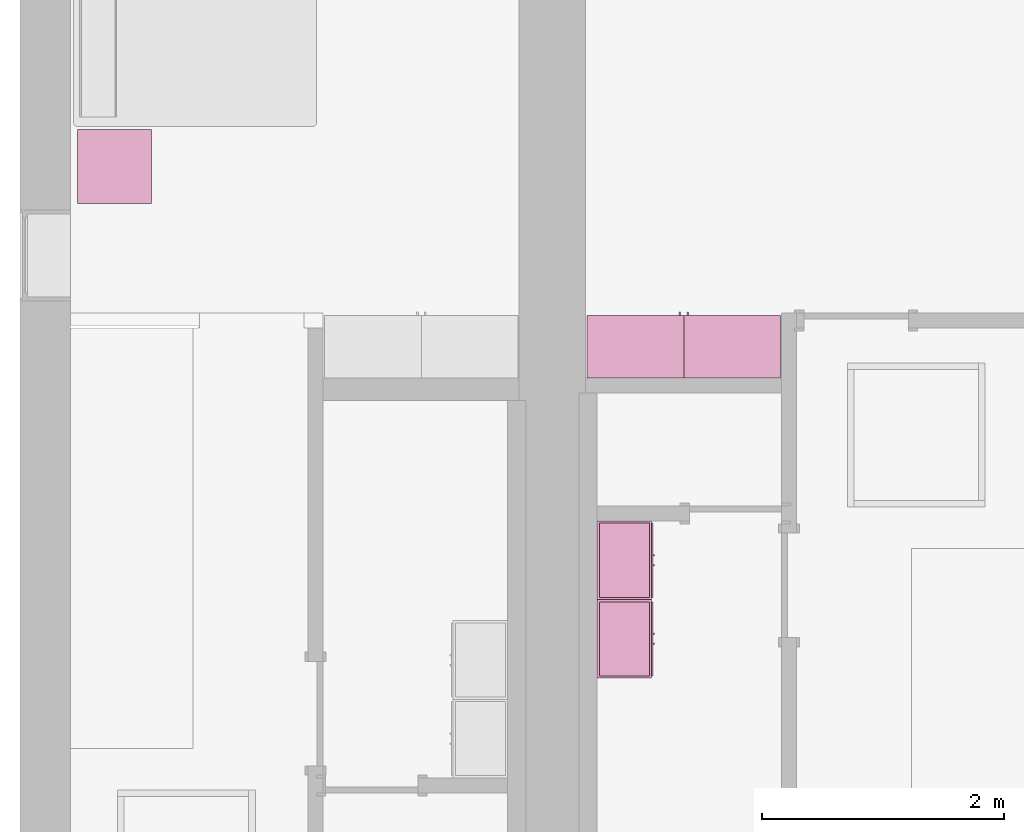
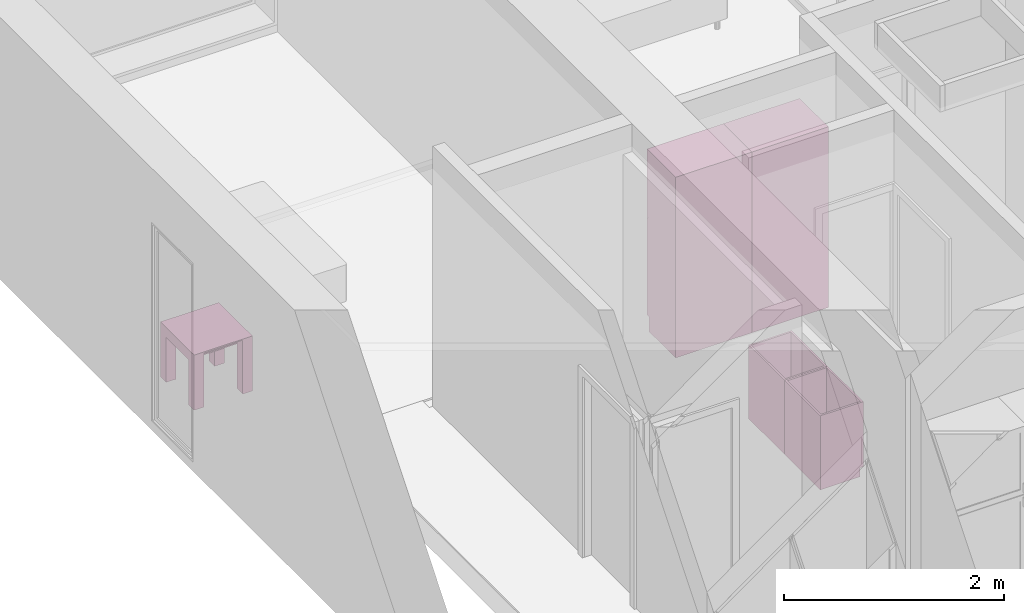
# One storey, part 11 of 14: 5 furnishings, 2 openings.
"""IFC2X3 building model written with IfcOpenShell, lengths in metres."""

import ifcopenshell
import ifcopenshell.guid

model = None  # the IFC model being written
_history = None  # IfcOwnerHistory: only IFC2X3 demands one
_inside = {}  # id of a spatial element -> (the spatial element, [elements in it])
_under = {}  # id of a project, library or spatial element -> (it, [spatial elements below it])
_declared = {}  # id of a project -> (the project, [libraries it declares])
_typed = {}  # id of a type object -> (the type object, [elements of that type])
_made_of = {}  # id of a material, layer set ... -> (it, [elements and type objects made of it])


def new_model(schema):
    """Start an empty IFC model of exactly this schema.

    Asked for "IFC4X3", IfcOpenShell would pick the latest addendum, in which some entities
    have other attributes; the version numbers below select the first issue.
    IFC2X3 requires an IfcOwnerHistory on every rooted entity: one is made here for all.
    """
    global model, _history
    if schema == "IFC4X3":
        model = ifcopenshell.file(schema_version=(4, 3, 0, 0))
    else:
        model = ifcopenshell.file(schema=schema)
    _inside.clear()
    _under.clear()
    _declared.clear()
    _typed.clear()
    _made_of.clear()
    _history = None
    if model.schema == "IFC2X3":
        org = make("IfcOrganization", Name="unknown")
        user = make(
            "IfcPersonAndOrganization",
            ThePerson=make("IfcPerson", FamilyName="unknown"),
            TheOrganization=org,
        )
        app = make(
            "IfcApplication",
            ApplicationDeveloper=org,
            Version="unknown",
            ApplicationFullName="unknown",
            ApplicationIdentifier="unknown",
        )
        _history = make(
            "IfcOwnerHistory",
            OwningUser=user,
            OwningApplication=app,
            ChangeAction="ADDED",
            CreationDate=0,
        )
    return model


def make(cls, **values):
    """One entity of the class cls with the attributes given. An attribute that is None is left unset."""
    return model.create_entity(
        cls, **{name: value for name, value in values.items() if value is not None}
    )


def entity(cls, *values):
    """Any entity or typed value of the class cls, its attributes in the order of the schema. None: left unset."""
    e = model.create_entity(cls)
    for i, value in enumerate(values):
        if value is not None:
            e[i] = value
    return e


def rooted(cls, **values):
    """An entity with a GlobalId (a new one), such as an element, a storey or a relation."""
    return make(cls, GlobalId=ifcopenshell.guid.new(), OwnerHistory=_history, **values)


def si_unit(unit_type, name, prefix=None):
    """IfcSIUnit, for example si_unit("LENGTHUNIT", "METRE", prefix="MILLI")."""
    return make("IfcSIUnit", UnitType=unit_type, Prefix=prefix, Name=name)


def converted_unit(unit_type, name, factor, base, dimensions=None, offset=None):
    """IfcConversionBasedUnit, such as the inch: factor (a typed value) times the base unit."""
    return make(
        "IfcConversionBasedUnit"
        if offset is None
        else "IfcConversionBasedUnitWithOffset",
        ConversionOffset=offset,
        Dimensions=None
        if dimensions is None
        else entity("IfcDimensionalExponents", *dimensions),
        UnitType=unit_type,
        Name=name,
        ConversionFactor=make(
            "IfcMeasureWithUnit", ValueComponent=factor, UnitComponent=base
        ),
    )


def assignment(units):
    """IfcUnitAssignment: the units of a project."""
    return None if units is None else make("IfcUnitAssignment", Units=units)


def point(xyz):
    """IfcCartesianPoint."""
    return None if xyz is None else make("IfcCartesianPoint", Coordinates=xyz)


def direction(xyz):
    """IfcDirection."""
    return None if xyz is None else make("IfcDirection", DirectionRatios=xyz)


def frame(location, z_axis=None, x_axis=None):
    """IfcAxis2Placement3D, a coordinate frame: its origin and axes. An axis left out is left unset."""
    return make(
        "IfcAxis2Placement3D",
        Location=point(location),
        Axis=direction(z_axis),
        RefDirection=direction(x_axis),
    )


def frame_2d(location, x_axis=None):
    """IfcAxis2Placement2D, a coordinate frame in the plane: its origin and x axis."""
    return make(
        "IfcAxis2Placement2D", Location=point(location), RefDirection=direction(x_axis)
    )


def origin():
    """The frame at (0, 0, 0) with its axes left unset."""
    return frame((0.0, 0.0, 0.0))


def origin_2d_with_axis():
    """The frame at (0, 0) in the plane with the x axis (1, 0) written out."""
    return frame_2d((0.0, 0.0), x_axis=(1.0, 0.0))


def place(relative_to, where):
    """IfcLocalPlacement: puts the frame where relative to a parent placement (None: the world)."""
    return make(
        "IfcLocalPlacement", PlacementRelTo=relative_to, RelativePlacement=where
    )


def context(
    kind, dimensions, precision=None, world=None, true_north=None, identifier=None
):
    """IfcGeometricRepresentationContext, for example the 3D "Model" context."""
    return make(
        "IfcGeometricRepresentationContext",
        ContextIdentifier=identifier,
        ContextType=kind,
        CoordinateSpaceDimension=dimensions,
        Precision=precision,
        WorldCoordinateSystem=world,
        TrueNorth=true_north,
    )


def project(units=None, contexts=None):
    """IfcProject with its units and contexts."""
    return rooted(
        "IfcProject",
        Name="project",
        RepresentationContexts=contexts,
        UnitsInContext=assignment(units),
    )


def spatial(cls, under=None, at=None, **own):
    """A site, building, storey or space (cls), placed at a placement, below another one or the project."""
    s = rooted(cls, ObjectPlacement=at, **own)
    if under is not None:
        _under.setdefault(under.id(), (under, []))[1].append(s)
    return s


def polyline(points):
    """IfcPolyline through the points."""
    return make("IfcPolyline", Points=[point(p) for p in points])


def profile(cls, at=None, kind="AREA", **sizes):
    """A parametric profile (cls). Its sizes go by their IFC names, for example OverallWidth=200.0."""
    return make(cls, ProfileType=kind, Position=at, **sizes)


def rectangle(**sizes):
    """IfcRectangleProfileDef."""
    return profile("IfcRectangleProfileDef", **sizes)


def outline(outer, holes=None, kind="AREA"):
    """IfcArbitraryClosedProfileDef: a profile drawn as a closed curve; with holes, ...WithVoids."""
    if holes is None:
        return make("IfcArbitraryClosedProfileDef", ProfileType=kind, OuterCurve=outer)
    return make(
        "IfcArbitraryProfileDefWithVoids",
        ProfileType=kind,
        OuterCurve=outer,
        InnerCurves=holes,
    )


def extrude(swept, where, along, depth):
    """IfcExtrudedAreaSolid: the profile swept, set in the frame where, extruded along a direction by depth."""
    return make(
        "IfcExtrudedAreaSolid",
        SweptArea=swept,
        Position=where,
        ExtrudedDirection=direction(along),
        Depth=depth,
    )


def faces_of(points, faces, orient=None, outer=None):
    """IfcFace entities. A face is a list of loops; a loop is a list of indices into points, from 0.

    orient and outer hold one flag for each loop. By default every Orientation is true, the
    first loop of a face is its IfcFaceOuterBound and the others are IfcFaceBound.
    """
    made = []
    for i, loops in enumerate(faces):
        bounds = []
        for j, loop in enumerate(loops):
            is_outer = j == 0 if outer is None else outer[i][j]
            bounds.append(
                make(
                    "IfcFaceOuterBound" if is_outer else "IfcFaceBound",
                    Bound=make("IfcPolyLoop", Polygon=[points[k] for k in loop]),
                    Orientation=True if orient is None else orient[i][j],
                )
            )
        made.append(make("IfcFace", Bounds=bounds))
    return made


def face_set(faces, orient=None, outer=None):
    """The faces of one IfcConnectedFaceSet. surface_model builds it on its shared points."""
    return ("IfcConnectedFaceSet", faces, orient, outer)


def surface_model(cls, points, shells):
    """IfcFaceBasedSurfaceModel or IfcShellBasedSurfaceModel (cls): surfaces that need not close."""
    shared = [point(p) for p in points]
    made = [make(c, CfsFaces=faces_of(shared, fs, o, b)) for c, fs, o, b in shells]
    if cls == "IfcFaceBasedSurfaceModel":
        return make(cls, FbsmFaces=made)
    return make(cls, SbsmBoundary=made)


def shape(context_of_items, identifier, shape_type, items):
    """IfcShapeRepresentation: the items that make up one representation, for example the "Body"."""
    return make(
        "IfcShapeRepresentation",
        ContextOfItems=context_of_items,
        RepresentationIdentifier=identifier,
        RepresentationType=shape_type,
        Items=items,
    )


def source(mapping_origin, context_of_items, identifier, shape_type, items):
    """IfcRepresentationMap: a shape defined once, which mapped items show again and again."""
    return make(
        "IfcRepresentationMap",
        MappingOrigin=mapping_origin,
        MappedRepresentation=shape(context_of_items, identifier, shape_type, items),
    )


def transform(
    local_origin,
    x_axis=None,
    y_axis=None,
    z_axis=None,
    scale=None,
    scale2=None,
    scale3=None,
    uniform=True,
):
    """IfcCartesianTransformationOperator3D, or its non-uniform kind. x_axis, y_axis, z_axis: its Axis1, 2, 3."""
    if uniform:
        return make(
            "IfcCartesianTransformationOperator3D",
            Axis1=direction(x_axis),
            Axis2=direction(y_axis),
            LocalOrigin=point(local_origin),
            Scale=scale,
            Axis3=direction(z_axis),
        )
    return make(
        "IfcCartesianTransformationOperator3DnonUniform",
        Axis1=direction(x_axis),
        Axis2=direction(y_axis),
        LocalOrigin=point(local_origin),
        Scale=scale,
        Axis3=direction(z_axis),
        Scale2=scale2,
        Scale3=scale3,
    )


def mapped(mapping_source, mapping_target):
    """IfcMappedItem: shows the shape of a source again, moved by a transform."""
    return make(
        "IfcMappedItem", MappingSource=mapping_source, MappingTarget=mapping_target
    )


def made_of(thing, what):
    """Note that an element or type object is made of a material, layer set ...; save() writes the relation."""
    if what is not None:
        _made_of.setdefault(what.id(), (what, []))[1].append(thing)
    return thing


def type_object(cls, material=None, **own):
    """A type object (cls), such as IfcWallType, which elements share."""
    return made_of(rooted(cls, **own), material)


def type_shapes(of_type, sources):
    """Give a type object the sources (RepresentationMaps) that its elements show as mapped items."""
    of_type.RepresentationMaps = sources


def element(
    cls,
    number,
    at=None,
    inside=None,
    cuts=None,
    type_object=None,
    material=None,
    context=None,
    identifier="Body",
    shape_type=None,
    held_by="IfcProductDefinitionShape",
    body=None,
    shapes=None,
    **own,
):
    """One element of the class cls, such as IfcWall. Its Tag is "e" and its number.

    at: its placement. inside: the storey or other place that contains it. cuts: it is an
    opening in that element (IfcRelVoidsElement). A single representation is given by context,
    identifier, shape_type and body (its items); several are given by shapes. held_by: the class
    of the entity that holds the representations. save() writes the other relations.
    """
    e = rooted(cls, Tag="e%d" % number, ObjectPlacement=at, **own)
    if body is not None:
        shapes = [shape(context, identifier, shape_type, body)]
    if shapes is not None:
        e.Representation = make(held_by, Representations=shapes)
    if inside is not None:
        _inside.setdefault(inside.id(), (inside, []))[1].append(e)
    if cuts is not None:
        rooted(
            "IfcRelVoidsElement", RelatingBuildingElement=cuts, RelatedOpeningElement=e
        )
    if type_object is not None:
        _typed.setdefault(type_object.id(), (type_object, []))[1].append(e)
    return made_of(e, material)


def aggregate(whole, parts):
    """IfcRelAggregates: a whole, such as a stair, and the parts it consists of."""
    return rooted("IfcRelAggregates", RelatingObject=whole, RelatedObjects=parts)


def save(model, path):
    """Write the relations noted so far, then the file.

    IfcRelAggregates (storeys below a building ...), IfcRelContainedInSpatialStructure (elements
    in a storey), IfcRelDefinesByType, IfcRelAssociatesMaterial and IfcRelDeclares: one each for
    every whole, place, type object, material and project.
    """
    for whole, parts in _under.values():
        aggregate(whole, parts)
    for where, things in _inside.values():
        rooted(
            "IfcRelContainedInSpatialStructure",
            RelatedElements=things,
            RelatingStructure=where,
        )
    for kind, things in _typed.values():
        rooted("IfcRelDefinesByType", RelatedObjects=things, RelatingType=kind)
    for what, things in _made_of.values():
        rooted("IfcRelAssociatesMaterial", RelatedObjects=things, RelatingMaterial=what)
    for by, libraries in _declared.values():
        rooted("IfcRelDeclares", RelatingContext=by, RelatedDefinitions=libraries)
    model.write(path)


model = new_model("IFC2X3")

# Units and contexts
model_context = context("Model", 3, precision=1e-09, world=origin())
plan_context = context("Plan", 3, precision=1e-09, world=origin())
ifc_project = project(units=[si_unit("LENGTHUNIT", "METRE"), si_unit("AREAUNIT", "SQUARE_METRE"), si_unit("VOLUMEUNIT", "CUBIC_METRE"), converted_unit("PLANEANGLEUNIT", "DEGREE", entity("IfcRatioMeasure", 0.01745329251994328), si_unit("PLANEANGLEUNIT", "RADIAN"), dimensions=[0, 0, 0, 0, 0, 0, 0]), si_unit("TIMEUNIT", "SECOND")], contexts=[model_context, plan_context])

# Site, building, storey, space
site_placement = place(None, origin())
site = spatial("IfcSite", under=ifc_project, at=site_placement, CompositionType="ELEMENT")
building_placement = place(site_placement, origin())
building = spatial("IfcBuilding", under=site, at=building_placement, CompositionType="ELEMENT")
storey_placement = place(building_placement, frame((0.0, 0.0, 3.100000000000378)))
storey = spatial("IfcBuildingStorey", under=building, at=storey_placement, Name="Level 2", CompositionType="ELEMENT", Elevation=3.100000000000378)
space_1_placement = place(storey_placement, origin())
space_1 = spatial("IfcSpace", under=storey, at=space_1_placement, CompositionType="ELEMENT", InteriorOrExteriorSpace="INTERNAL")

# Furnishing
furniture_type_1 = type_object("IfcFurnitureType", Name="0610 x 0610 x 0610mm", AssemblyPlace="NOTDEFINED")
shared_shape_1 = source(origin(), model_context, "Body", "SweptSolid", [
    extrude(rectangle(XDim=0.4067999999999992, YDim=0.4067999999999995, at=origin_2d_with_axis()), frame((0.01826576667263163, 0.09521107780222626, 0.4957000000000002), z_axis=(0.0, 0.0, 1.0), x_axis=(-1.0, 0.0, 0.0)), (0.0, 0.0, 1.0), 0.01270000000000002),
    extrude(outline(polyline([(-0.2732499999999937, -0.3050000000000002), (0.3240499999999779, -0.3050000000000002), (0.3240499999999779, 0.3049999999999985), (-0.2732499999999932, 0.3049999999999986), (-0.2732499999999932, 0.2034000000000015), (0.2224500000000091, 0.2034000000000015), (0.2224500000000091, -0.2033999999999998), (-0.2732499999999936, -0.2033999999999998), (-0.2732499999999937, -0.3050000000000002)])), frame((0.2216657666726329, 0.09521107780223541, 0.2732499999999923), z_axis=(1.0, 0.0, 0.0), x_axis=(0.0, 0.0, 1.0)), (0.0, 0.0, 1.0), 0.1016),
    extrude(outline(polyline([(-0.3050000000000043, -0.3240500000000255), (0.3049999999999944, -0.3240500000000255), (0.3049999999999944, 0.2732500000000109), (0.2034000000000044, 0.2732500000000109), (0.2034000000000044, -0.2224499999999962), (-0.2033999999999945, -0.2224499999999962), (-0.2033999999999945, 0.2732500000000109), (-0.3050000000000043, 0.2732500000000109), (-0.3050000000000043, -0.3240500000000255)])), frame((-0.2867342333273671, 0.09521107780222562, 0.2732500000000078), z_axis=(1.0, 0.0, 0.0), x_axis=(0.0, -1.0, 0.0)), (0.0, 0.0, 1.0), 0.1016),
    extrude(rectangle(XDim=0.4067999999999992, YDim=0.4067999999999995, at=origin_2d_with_axis()), frame((0.01826576667263163, 0.09521107780222593, 0.5973000000000002), z_axis=(0.0, 0.0, 1.0), x_axis=(-1.0, 0.0, 0.0)), (0.0, 0.0, 1.0), 0.01270000000000002),
    extrude(outline(polyline([(-0.3050000000000005, -0.3050000000000226), (0.3050000000000004, -0.3050000000000226), (0.3050000000000005, 0.3050000000000226), (-0.3050000000000004, 0.3050000000000226), (-0.3050000000000005, -0.3050000000000226)]), holes=[polyline([(-0.203399999999998, -0.2033999999999748), (-0.2033999999999979, 0.2034000000000246), (0.2034000000000013, 0.2034000000000245), (0.2034000000000012, -0.2033999999999749), (-0.203399999999998, -0.2033999999999748)])]), frame((0.01826576667263323, 0.09521107780225081, 0.5973000000000003), z_axis=(0.0, 0.0, 1.0), x_axis=(-1.0, 0.0, 0.0)), (0.0, 0.0, 1.0), 0.01269999999999996),
])
type_shapes(furniture_type_1, [shared_shape_1])
furnishing_1_placement = place(space_1_placement, frame((0.7637342333273673, -5.012211077802231, 0.01899999999981805)))
element("IfcFurnishingElement", 1, at=furnishing_1_placement, inside=space_1, type_object=furniture_type_1, Name="M_Table-Coffee:0610 x 0610 x 0610mm:0610 x 0610 x 0610mm", ObjectType="0610 x 0610 x 0610mm", context=model_context, shape_type="MappedRepresentation", body=[
    mapped(shared_shape_1, transform((0.0, 0.0, 0.0), scale=1.0)),
])

# Space
space_2_placement = place(storey_placement, origin())
space_2 = spatial("IfcSpace", under=storey, at=space_2_placement, CompositionType="ELEMENT", InteriorOrExteriorSpace="INTERNAL")

# Furnishing, opening
furniture_type_2 = type_object("IfcFurnitureType", Name="800 mm", AssemblyPlace="NOTDEFINED")
shared_shape_2 = source(origin(), model_context, "Body", "SurfaceModel", [
    surface_model("IfcFaceBasedSurfaceModel", [(0.7999999999999998, 0.04444999999999991, 0.1615874999998423), (0.0, 0.04445000000000255, 0.1615874999998423), (0.0, 0.04445000000000255, 2.0), (0.7999999999999998, 0.04444999999999991, 2.0), (0.7809499999999974, 0.04444999999999998, 1.980949999999954), (0.01904999999999817, 0.04445000000000248, 1.980949999999954), (0.01904999999999817, 0.04445000000000248, 0.1806374999998427), (0.7809499999999974, 0.04444999999999998, 0.1806374999998428), (0.0, 0.5454000000000022, 2.0), (0.8000000000000014, 0.5453999999999996, 2.0), (0.8000000000000026, 0.5453999999999996, 0.0), (0.0, 0.5454000000000009, 0.0), (0.780949999999999, 0.5453999999999996, 1.980949999999954), (0.0190499999999998, 0.5454000000000021, 1.980949999999954), (0.0190499999999998, 0.5454000000000021, 0.1806374999998428), (0.780949999999999, 0.5453999999999996, 0.1806374999998428), (0.7999999999999999, 0.06040000000000177, 0.1615874999998423), (0.7999999999999999, 0.06040000000000177, 0.0), (0.0, 0.06040000000000177, 0.0), (0.0, 0.06040000000000177, 0.1615874999998318), (0.7745999999999997, 0.0, 1.371548036695815), (0.7745999999999997, 0.0, 1.269948036695815), (0.7620677683693553, 0.0, 1.269948036695815), (0.7620677683693553, 0.0, 1.371548036695815), (0.7745999999999988, 0.0, 1.219148036695816), (0.7745999999999988, 0.0, 1.117548036695818), (0.7620677683693542, 0.0, 1.117548036695818), (0.7620677683693542, 0.0, 1.219148036695816), (0.7745999999999998, 0.02539999999999998, 1.371548036695815), (0.7745999999999998, 0.02539999999999998, 1.269948036695815), (0.7620677683693555, 0.02540000000000005, 1.269948036695815), (0.7620677683693555, 0.02540000000000005, 1.371548036695815), (0.7745999999999988, 0.02539999999999998, 1.219148036695816), (0.7745999999999988, 0.02539999999999998, 1.117548036695818), (0.7620677683693542, 0.02540000000000005, 1.117548036695818), (0.7620677683693542, 0.02540000000000005, 1.219148036695816), (0.7364999999999996, 0.03810000000000007, 1.936499999999956), (0.7364999999999996, 0.03810000000000007, 1.308048036695816), (0.06350000000000126, 0.03810000000000231, 1.308048036695816), (0.06350000000000126, 0.03810000000000231, 1.936499999999956), (0.736499999999999, 0.03810000000000007, 1.181048036695814), (0.736499999999999, 0.03810000000000007, 0.2250874999998395), (0.06350000000000072, 0.03810000000000231, 0.2250874999998395), (0.06350000000000072, 0.03810000000000231, 1.181048036695814), (0.7364999999999996, 0.04445000000000005, 1.936499999999956), (0.7364999999999996, 0.04445000000000005, 1.308048036695816), (0.06350000000000126, 0.04445000000000228, 1.308048036695816), (0.06350000000000126, 0.04445000000000228, 1.936499999999956), (0.736499999999999, 0.04445000000000005, 1.181048036695814), (0.736499999999999, 0.04445000000000005, 0.2250874999998395), (0.06350000000000072, 0.04445000000000228, 0.2250874999998395), (0.06350000000000072, 0.04445000000000228, 1.181048036695814), (0.8, 0.02539999999999984, 2.0), (0.8, 0.02539999999999984, 1.247723036695813), (0.0, 0.02540000000000248, 1.247723036695813), (0.0, 0.02540000000000248, 2.0), (0.7364999999999996, 0.02540000000000005, 1.936499999999956), (0.0635000000000012, 0.02540000000000228, 1.936499999999956), (0.0635000000000012, 0.02540000000000228, 1.308048036695816), (0.7364999999999996, 0.02540000000000005, 1.308048036695816), (0.7999999999999998, 0.02539999999999984, 0.1615874999998214), (0.0, 0.02540000000000248, 0.1615874999998214), (0.0, 0.02540000000000248, 1.241373036695815), (0.7999999999999998, 0.02539999999999984, 1.241373036695815), (0.736499999999999, 0.02540000000000005, 1.181048036695817), (0.06350000000000065, 0.02540000000000228, 1.181048036695817), (0.06350000000000065, 0.02540000000000228, 0.2250874999998395), (0.736499999999999, 0.02540000000000005, 0.2250874999998395), (0.8000000000000002, 0.04444999999999984, 2.0), (0.8000000000000002, 0.04444999999999984, 1.247723036695813), (0.0, 0.04445000000000248, 1.247723036695813), (0.0, 0.04445000000000248, 2.0), (0.7999999999999999, 0.04444999999999984, 0.1615874999998214), (0.0, 0.04445000000000248, 0.1615874999998214), (0.0, 0.04445000000000248, 1.241373036695815), (0.7999999999999999, 0.04444999999999984, 1.241373036695815), (0.736499999999999, 0.04445000000000005, 1.181048036695817), (0.06350000000000072, 0.04445000000000228, 1.181048036695817), (0.7809499999999987, 0.5263500000000009, 1.980949999999952), (0.7809499999999988, 0.5263500000000009, 0.1806374999998463), (0.01904999999999987, 0.5263500000000009, 0.1806374999998463), (0.0190499999999998, 0.5263500000000009, 1.980949999999952), (0.7809499999999987, 0.5454000000000009, 1.980949999999952), (0.7809499999999987, 0.5454000000000009, 0.1806374999998463), (0.0190499999999998, 0.5454000000000009, 0.1806374999998463), (0.0190499999999998, 0.5454000000000009, 1.980949999999952)], [face_set([[[0, 1, 2, 3], [4, 5, 6, 7]], [[8, 9, 10, 11], [12, 13, 14, 15]], [[3, 0, 16, 17, 10, 9]], [[2, 8, 9, 3]], [[1, 2, 8, 11, 18, 19]], [[0, 1, 19, 16]], [[7, 15, 12, 4]], [[6, 14, 15, 7]], [[5, 13, 14, 6]], [[4, 5, 13, 12]], [[10, 17, 18, 11]], [[18, 19, 16, 17]]]), face_set([[[20, 21, 22, 23]], [[24, 25, 26, 27]], [[28, 29, 30, 31]], [[32, 33, 34, 35]], [[23, 31, 28, 20]], [[22, 23, 31, 30]], [[21, 22, 30, 29]], [[20, 28, 29, 21]], [[27, 35, 32, 24]], [[26, 27, 35, 34]], [[25, 26, 34, 33]], [[24, 32, 33, 25]]]), face_set([[[36, 37, 38, 39]], [[40, 41, 42, 43]], [[44, 45, 46, 47]], [[48, 49, 50, 51]], [[39, 47, 44, 36]], [[38, 46, 47, 39]], [[37, 38, 46, 45]], [[36, 37, 45, 44]], [[43, 51, 48, 40]], [[42, 50, 51, 43]], [[41, 42, 50, 49]], [[40, 41, 49, 48]]]), face_set([[[52, 53, 54, 55], [56, 57, 58, 59]], [[60, 61, 62, 63], [64, 65, 66, 67]], [[68, 69, 70, 71], [44, 47, 46, 45]], [[72, 73, 74, 75], [76, 77, 50, 49]], [[55, 71, 68, 52]], [[54, 55, 71, 70]], [[53, 54, 70, 69]], [[52, 53, 69, 68]], [[63, 60, 72, 75]], [[62, 74, 75, 63]], [[61, 62, 74, 73]], [[60, 61, 73, 72]], [[59, 45, 44, 56]], [[58, 46, 45, 59]], [[57, 58, 46, 47]], [[56, 57, 47, 44]], [[67, 49, 76, 64]], [[66, 50, 49, 67]], [[65, 66, 50, 77]], [[64, 65, 77, 76]]]), face_set([[[78, 79, 80, 81]], [[82, 83, 84, 85]], [[81, 85, 82, 78]], [[80, 81, 85, 84]], [[79, 80, 84, 83]], [[78, 79, 83, 82]]])]),
])
type_shapes(furniture_type_2, [shared_shape_2])
furnishing_2_placement = place(space_2_placement, frame((6.286000000000011, -6.120600000000008, 0.0), z_axis=(0.0, 0.0, 1.0), x_axis=(-1.0, 0.0, 0.0)))
furnishing_2 = element("IfcFurnishingElement", 2, at=furnishing_2_placement, inside=space_2, type_object=furniture_type_2, ObjectType="800 mm", context=model_context, shape_type="MappedRepresentation", body=[
    mapped(shared_shape_2, transform((0.0, 0.0, 0.0), scale=1.0)),
])
opening_1_placement = place(space_2_placement, frame((6.286000000000011, -6.120600000000008, 0.0), z_axis=(0.0, 0.0, 1.0), x_axis=(-1.0, 0.0, 0.0)))
element("IfcOpeningElement", 3, at=opening_1_placement, cuts=furnishing_2, ObjectType="Opening", context=model_context, shape_type="SweptSolid", body=[
    extrude(rectangle(XDim=1.800312500000111, YDim=0.7618999999999992, at=origin_2d_with_axis()), frame((-0.01873770491802666, 0.5009499999999996, -2.01920625000048), z_axis=(0.0, -1.0, 0.0), x_axis=(0.0, 0.0, -1.0)), (0.0, 0.0, 1.0), 0.5009499999999997),
])

furniture_type_3 = type_object("IfcFurnitureType", Name="800 mm", AssemblyPlace="NOTDEFINED")
shared_shape_3 = source(origin(), model_context, "Body", "SurfaceModel", [
    surface_model("IfcFaceBasedSurfaceModel", [(0.7999999999999998, 0.5009500000000022, 0.1615874999998423), (0.7999999999999998, 0.5009500000000022, 2.0), (0.0, 0.5009499999999997, 2.0), (0.0, 0.5009499999999997, 0.1615874999998423), (0.7809499999999974, 0.5009500000000022, 1.980949999999954), (0.7809499999999974, 0.5009500000000022, 0.1806374999998428), (0.01904999999999817, 0.5009499999999997, 0.1806374999998428), (0.01904999999999817, 0.5009499999999997, 1.980949999999954), (0.0, 0.0, 2.0), (0.0, 0.0, 0.0), (0.8000000000000026, 0.0, 0.0), (0.8000000000000014, 0.0, 2.0), (0.780949999999999, 0.0, 1.980949999999954), (0.780949999999999, 0.0, 0.1806374999998428), (0.0190499999999998, 0.0, 0.1806374999998427), (0.0190499999999998, 0.0, 1.980949999999954), (0.8000000000000026, 0.4850000000000004, 0.0), (0.7999999999999999, 0.4850000000000004, 0.1615874999998318), (0.0, 0.4850000000000004, 0.0), (0.0, 0.4850000000000004, 0.1615874999998423), (0.7745999999999997, 0.5454000000000022, 1.371548036695815), (0.7620677683693553, 0.5454000000000021, 1.371548036695815), (0.7620677683693553, 0.5454000000000021, 1.269948036695815), (0.7745999999999997, 0.5454000000000022, 1.269948036695815), (0.7745999999999988, 0.5454000000000022, 1.219148036695816), (0.7620677683693542, 0.5454000000000021, 1.219148036695816), (0.7620677683693542, 0.5454000000000021, 1.117548036695818), (0.7745999999999988, 0.5454000000000022, 1.117548036695818), (0.7745999999999998, 0.5200000000000022, 1.371548036695815), (0.7620677683693555, 0.5200000000000021, 1.371548036695815), (0.7620677683693555, 0.5200000000000021, 1.269948036695815), (0.7745999999999998, 0.5200000000000022, 1.269948036695815), (0.7745999999999988, 0.5200000000000022, 1.219148036695816), (0.7620677683693542, 0.5200000000000021, 1.219148036695816), (0.7620677683693542, 0.5200000000000021, 1.117548036695818), (0.7745999999999988, 0.5200000000000022, 1.117548036695818), (0.7364999999999996, 0.5073000000000021, 1.936499999999956), (0.06350000000000126, 0.5072999999999999, 1.936499999999956), (0.06350000000000126, 0.5072999999999999, 1.308048036695816), (0.7364999999999996, 0.5073000000000021, 1.308048036695816), (0.736499999999999, 0.5073000000000021, 1.181048036695814), (0.06350000000000072, 0.5072999999999999, 1.181048036695814), (0.06350000000000072, 0.5072999999999999, 0.2250874999998395), (0.736499999999999, 0.5073000000000021, 0.2250874999998395), (0.7364999999999996, 0.5009500000000021, 1.936499999999956), (0.06350000000000126, 0.5009499999999999, 1.936499999999956), (0.06350000000000126, 0.5009499999999999, 1.308048036695816), (0.7364999999999996, 0.5009500000000021, 1.308048036695816), (0.736499999999999, 0.5009500000000021, 1.181048036695814), (0.06350000000000072, 0.5009499999999999, 1.181048036695814), (0.06350000000000072, 0.5009499999999999, 0.2250874999998395), (0.736499999999999, 0.5009500000000021, 0.2250874999998395), (0.8, 0.5200000000000023, 2.0), (0.0, 0.5199999999999997, 2.0), (0.0, 0.5199999999999997, 1.247723036695813), (0.8, 0.5200000000000023, 1.247723036695813), (0.7364999999999996, 0.5200000000000021, 1.936499999999956), (0.7364999999999996, 0.5200000000000021, 1.308048036695816), (0.0635000000000012, 0.5199999999999999, 1.308048036695816), (0.0635000000000012, 0.5199999999999999, 1.936499999999956), (0.7999999999999998, 0.5200000000000023, 0.1615874999998214), (0.7999999999999998, 0.5200000000000023, 1.241373036695815), (0.0, 0.5199999999999997, 1.241373036695815), (0.0, 0.5199999999999997, 0.1615874999998214), (0.736499999999999, 0.5200000000000021, 1.181048036695817), (0.736499999999999, 0.5200000000000021, 0.2250874999998395), (0.06350000000000065, 0.5199999999999999, 0.2250874999998395), (0.06350000000000065, 0.5199999999999999, 1.181048036695817), (0.8000000000000002, 0.5009500000000023, 2.0), (0.0, 0.5009499999999997, 1.247723036695813), (0.8, 0.5009500000000023, 1.247723036695813), (0.7999999999999999, 0.5009500000000023, 0.1615874999998214), (0.7999999999999999, 0.5009500000000023, 1.241373036695815), (0.0, 0.5009499999999997, 1.241373036695815), (0.0, 0.5009499999999997, 0.1615874999998214), (0.736499999999999, 0.5009500000000021, 1.181048036695817), (0.06350000000000072, 0.5009499999999999, 1.181048036695817), (0.7809499999999987, 0.01905000000000129, 1.980949999999952), (0.0190499999999998, 0.01905000000000129, 1.980949999999952), (0.0190499999999998, 0.01905000000000129, 0.1806374999998463), (0.7809499999999987, 0.01905000000000129, 0.1806374999998463), (0.7809499999999987, 0.0, 1.980949999999952), (0.0190499999999998, 0.0, 1.980949999999952), (0.01904999999999987, 0.0, 0.1806374999998463), (0.7809499999999988, 0.0, 0.1806374999998463)], [face_set([[[0, 1, 2, 3], [4, 5, 6, 7]], [[8, 9, 10, 11], [12, 13, 14, 15]], [[1, 11, 10, 16, 17, 0]], [[2, 1, 11, 8]], [[3, 2, 8, 9, 18, 19]], [[0, 17, 19, 3]], [[5, 4, 12, 13]], [[6, 5, 13, 14]], [[7, 6, 14, 15]], [[4, 12, 15, 7]], [[10, 9, 18, 16]], [[18, 16, 17, 19]]]), face_set([[[20, 21, 22, 23]], [[24, 25, 26, 27]], [[28, 29, 30, 31]], [[32, 33, 34, 35]], [[21, 20, 28, 29]], [[22, 30, 29, 21]], [[23, 31, 30, 22]], [[20, 23, 31, 28]], [[25, 24, 32, 33]], [[26, 34, 33, 25]], [[27, 35, 34, 26]], [[24, 27, 35, 32]]]), face_set([[[36, 37, 38, 39]], [[40, 41, 42, 43]], [[44, 45, 46, 47]], [[48, 49, 50, 51]], [[37, 36, 44, 45]], [[38, 37, 45, 46]], [[39, 47, 46, 38]], [[36, 44, 47, 39]], [[41, 40, 48, 49]], [[42, 41, 49, 50]], [[43, 51, 50, 42]], [[40, 48, 51, 43]]]), face_set([[[52, 53, 54, 55], [56, 57, 58, 59]], [[60, 61, 62, 63], [64, 65, 66, 67]], [[68, 2, 69, 70], [44, 47, 46, 45]], [[71, 72, 73, 74], [75, 51, 50, 76]], [[53, 52, 68, 2]], [[54, 69, 2, 53]], [[55, 70, 69, 54]], [[52, 68, 70, 55]], [[61, 72, 71, 60]], [[62, 61, 72, 73]], [[63, 74, 73, 62]], [[60, 71, 74, 63]], [[57, 56, 44, 47]], [[58, 57, 47, 46]], [[59, 45, 46, 58]], [[56, 44, 45, 59]], [[65, 64, 75, 51]], [[66, 65, 51, 50]], [[67, 76, 50, 66]], [[64, 75, 76, 67]]]), face_set([[[77, 78, 79, 80]], [[81, 82, 83, 84]], [[78, 77, 81, 82]], [[79, 83, 82, 78]], [[80, 84, 83, 79]], [[77, 81, 84, 80]]])]),
])
type_shapes(furniture_type_3, [shared_shape_3])
furnishing_3_placement = place(space_2_placement, frame((4.686000000000006, -6.665999999999998, 0.0)))
furnishing_3 = element("IfcFurnishingElement", 4, at=furnishing_3_placement, inside=space_2, type_object=furniture_type_3, ObjectType="800 mm", context=model_context, shape_type="MappedRepresentation", body=[
    mapped(shared_shape_3, transform((0.0, 0.0, 0.0), scale=1.0)),
])
opening_2_placement = place(space_2_placement, frame((4.686000000000006, -6.665999999999998, 0.0)))
element("IfcOpeningElement", 5, at=opening_2_placement, cuts=furnishing_3, ObjectType="Opening", context=model_context, shape_type="SweptSolid", body=[
    extrude(rectangle(XDim=1.800312500000111, YDim=0.7618999999999992, at=origin_2d_with_axis()), frame((0.01873770491802511, 0.0, -2.01920625000048), z_axis=(0.0, 1.0, 0.0), x_axis=(0.0, 0.0, -1.0)), (0.0, 0.0, 1.0), 0.5009499999999997),
])

# Space
space_3_placement = place(storey_placement, origin())
space_3 = spatial("IfcSpace", under=storey, at=space_3_placement, CompositionType="ELEMENT", InteriorOrExteriorSpace="INTERNAL")

# Furnishings
furniture_type_4 = type_object("IfcFurnitureType", Name="650 x 450 mm", AssemblyPlace="NOTDEFINED")
shared_shape_4 = source(origin(), model_context, "Body", "SurfaceModel", [
    surface_model("IfcFaceBasedSurfaceModel", [(0.6309500000000011, 0.430950000000001, 0.8199999999999998), (0.01904999999999871, 0.430950000000001, 0.8199999999999998), (0.01904999999999871, 0.430950000000001, 0.09999999999999946), (0.6309500000000011, 0.430950000000001, 0.09999999999999946), (0.0, 0.4499999999999997, 0.8199999999999998), (0.6499999999999999, 0.4499999999999997, 0.8199999999999998), (0.0, 0.4499999999999997, 0.09999999999999946), (0.6499999999999999, 0.4499999999999997, 0.09999999999999946), (0.01904999999999871, 0.4149999999999978, 0.09999999999999944), (0.01904999999999871, 0.01904999999999871, 0.09999999999999946), (0.01904999999999871, 0.01904999999999871, 0.8199999999999998), (0.0, 0.0, 0.8199999999999998), (0.0, 0.0, 0.0), (0.0, 0.4149999999999978, 0.0), (0.0, 0.4149999999999978, 0.09999999999999946), (0.6309500000000011, 0.01904999999999869, 0.09999999999999946), (0.6309500000000011, 0.01904999999999869, 0.8199999999999998), (0.6499999999999999, 0.0, 0.8199999999999998), (0.6499999999999999, 0.0, 0.0), (0.6309500000000011, 0.4149999999999978, 0.09999999999999946), (0.6499999999999999, 0.4149999999999978, 0.0), (0.6499999999999999, 0.4149999999999978, 0.09999999999999946), (0.2900749999999994, 0.4753999999999998, 0.6422000000000013), (0.2773749999999991, 0.4753999999999997, 0.6422000000000013), (0.2773749999999991, 0.4753999999999997, 0.5174698950351613), (0.2900749999999994, 0.4753999999999998, 0.5174698950351613), (0.3726249999999207, 0.4754, 0.6422000000000011), (0.3599249999999205, 0.4753999999999999, 0.6422000000000011), (0.3599249999999205, 0.4753999999999999, 0.5174698950351634), (0.3726249999999207, 0.4754, 0.5174698950351634), (0.2900749999999994, 0.4626999999999997, 0.6422000000000013), (0.2773749999999991, 0.4626999999999997, 0.6422000000000013), (0.2773749999999991, 0.4626999999999997, 0.5174698950351613), (0.2900749999999994, 0.4626999999999997, 0.5174698950351613), (0.3726249999999207, 0.4627, 0.6422000000000011), (0.3599249999999206, 0.4626999999999999, 0.6422000000000011), (0.3599249999999206, 0.4626999999999999, 0.5174698950351634), (0.3726249999999207, 0.4627, 0.5174698950351634), (0.3154749999998973, 0.4626999999999997, 0.6803000000000058), (0.01905000000047931, 0.4626999999999988, 0.6803000000000058), (0.01905000000047931, 0.4626999999999988, 0.1190499999998422), (0.3154749999998973, 0.4626999999999997, 0.1190499999998422), (0.6309500000005075, 0.4627000000000007, 0.6803000000000425), (0.3345249999998469, 0.4626999999999998, 0.6803000000000425), (0.3345249999998469, 0.4626999999999998, 0.1190499999998571), (0.6309500000005075, 0.4627000000000007, 0.1190499999998571), (0.6309500000005104, 0.4627000000000007, 0.8009500000000862), (0.01905000000049125, 0.4626999999999988, 0.8009500000000862), (0.01905000000049122, 0.4626999999999988, 0.699350000000061), (0.6309500000005104, 0.4627000000000007, 0.699350000000061), (0.3154749999998973, 0.4499999999999997, 0.6803000000000058), (0.01905000000047934, 0.4499999999999987, 0.6803000000000058), (0.01905000000047934, 0.4499999999999987, 0.1190499999998422), (0.3154749999998973, 0.4499999999999997, 0.1190499999998422), (0.6309500000005075, 0.4500000000000007, 0.6803000000000425), (0.3345249999998469, 0.4499999999999998, 0.6803000000000425), (0.3345249999998469, 0.4499999999999998, 0.1190499999998571), (0.6309500000005075, 0.4500000000000007, 0.1190499999998571), (0.6309500000005104, 0.4500000000000007, 0.8009500000000862), (0.01905000000049135, 0.4499999999999987, 0.8009500000000862), (0.01905000000049129, 0.4499999999999987, 0.699350000000061), (0.6309500000005104, 0.4500000000000007, 0.699350000000061), (0.6309500000000011, 0.01904999999999871, 0.119049999999842), (0.01904999999999871, 0.01904999999999871, 0.119049999999842), (0.01904999999999871, 0.430950000000001, 0.119049999999842), (0.6309500000000011, 0.430950000000001, 0.119049999999842), (0.6309500000000011, 0.01904999999999872, 0.09999999999999944), (0.01904999999999871, 0.01904999999999871, 0.09999999999999944), (0.01904999999999871, 0.430950000000001, 0.09999999999999944), (0.6309500000000011, 0.430950000000001, 0.09999999999999944)], [face_set([[[0, 1, 2, 3]], [[0, 1, 4, 5]], [[5, 4, 6, 7]], [[2, 6, 7, 3]], [[1, 2, 8, 9, 10]], [[4, 1, 10, 11]], [[6, 4, 11, 12, 13, 14]], [[2, 8, 14, 6]], [[10, 9, 15, 16]], [[11, 10, 16, 17]], [[12, 18, 17, 11]], [[3, 0, 16, 15, 19]], [[0, 5, 17, 16]], [[5, 17, 18, 20, 21, 7]], [[7, 21, 19, 3]], [[8, 19, 15, 9]], [[18, 12, 13, 20]], [[13, 20, 21, 19, 8, 14]]]), face_set([[[22, 23, 24, 25]], [[26, 27, 28, 29]], [[30, 31, 32, 33]], [[34, 35, 36, 37]], [[23, 22, 30, 31]], [[24, 23, 31, 32]], [[25, 33, 32, 24]], [[22, 30, 33, 25]], [[27, 26, 34, 35]], [[28, 27, 35, 36]], [[29, 37, 36, 28]], [[26, 34, 37, 29]]]), face_set([[[38, 39, 40, 41]], [[42, 43, 44, 45]], [[46, 47, 48, 49]], [[50, 51, 52, 53]], [[54, 55, 56, 57]], [[58, 59, 60, 61]], [[39, 38, 50, 51]], [[40, 52, 51, 39]], [[41, 53, 52, 40]], [[38, 50, 53, 41]], [[43, 42, 54, 55]], [[44, 43, 55, 56]], [[45, 57, 56, 44]], [[42, 54, 57, 45]], [[47, 46, 58, 59]], [[48, 60, 59, 47]], [[49, 61, 60, 48]], [[46, 58, 61, 49]]]), face_set([[[62, 63, 64, 65]], [[66, 67, 68, 69]], [[63, 67, 66, 62]], [[64, 68, 67, 63]], [[65, 64, 68, 69]], [[62, 66, 69, 65]]])]),
])
type_shapes(furniture_type_4, [shared_shape_4])
for number, where, z_axis, x_axis in (
    (6, (4.770000000000015, -7.845384235071528, 0.01299999999981782), (0.0, 0.0, 1.0), (0.0, -1.0, 0.0)),
    (7, (4.770000000000017, -8.495384235071528, 0.01299999999981782), (0.0, 0.0, 1.0), (0.0, -1.0, 0.0)),
):
    element("IfcFurnishingElement", number, at=place(space_3_placement, frame(where, z_axis=z_axis, x_axis=x_axis)), inside=space_3, type_object=furniture_type_4, ObjectType="650 x 450 mm", context=model_context, shape_type="MappedRepresentation", body=[
        mapped(shared_shape_4, transform((0.0, 0.0, 0.0), scale=1.0)),
    ])

save(model, "model.ifc")
